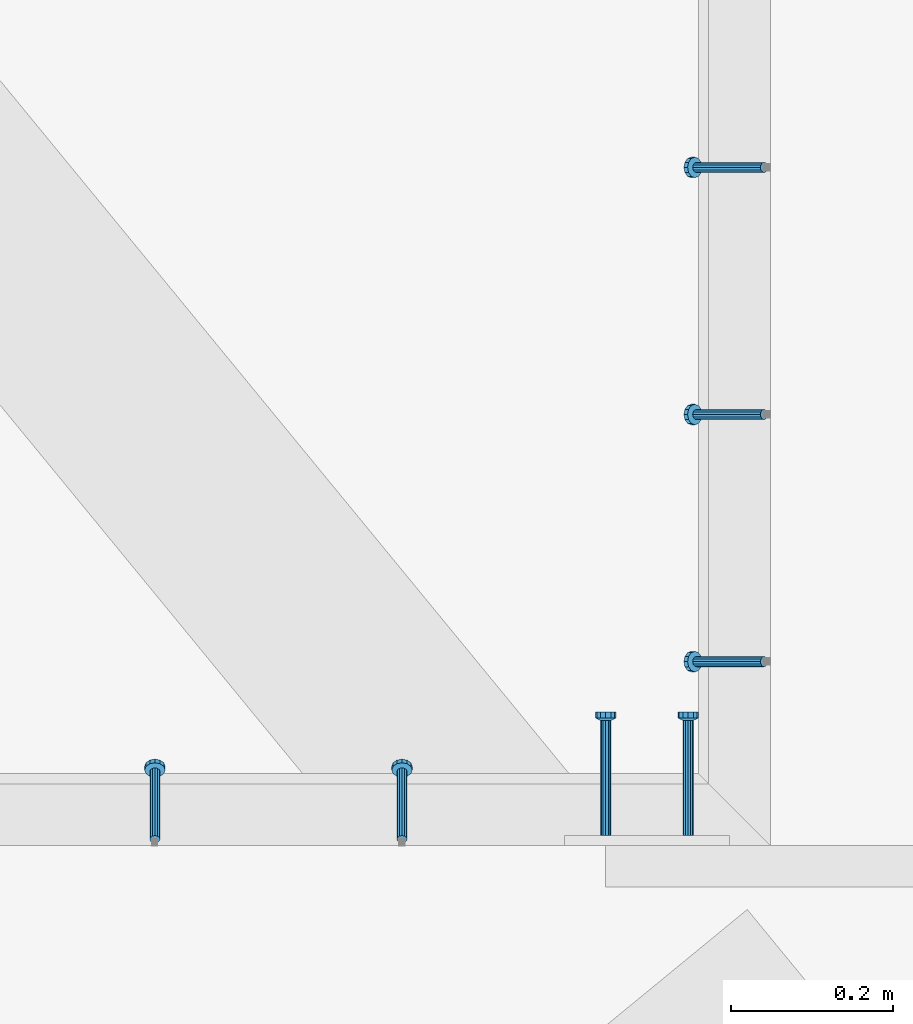
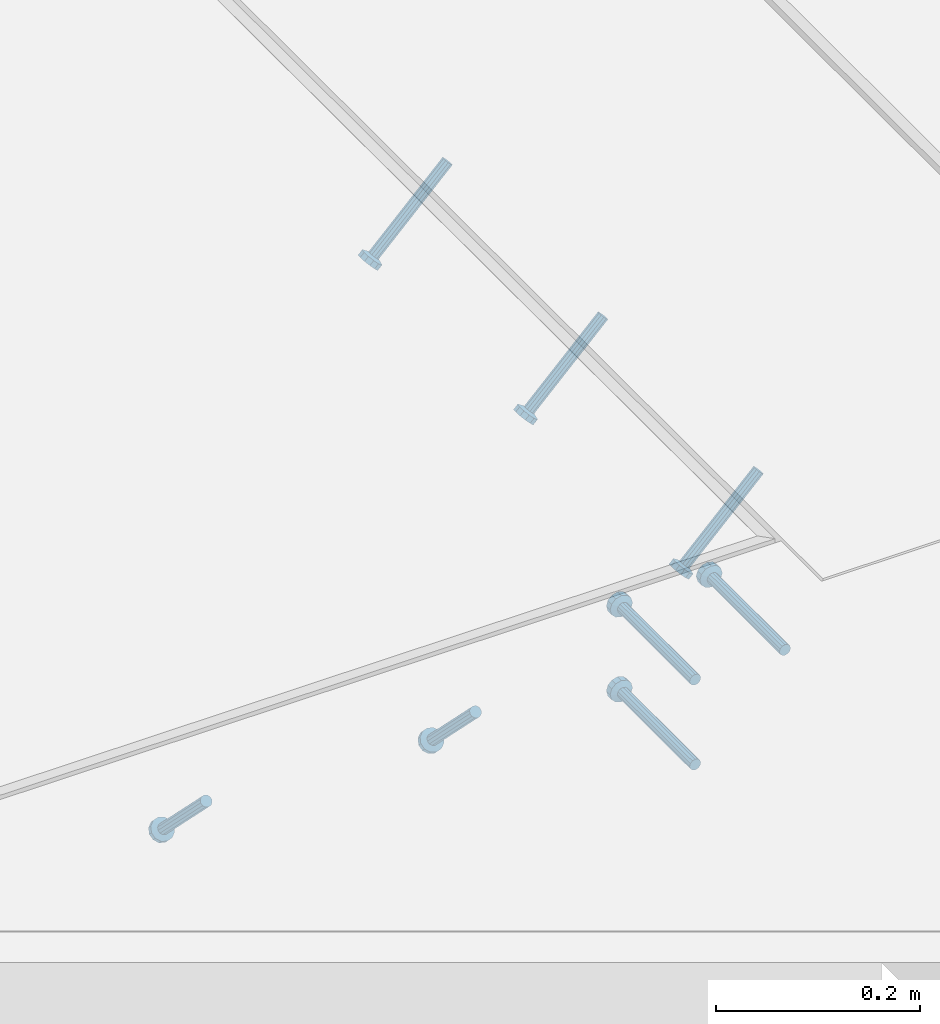
# One storey, part 2110 of 3843: 5 members, 3 beams, 3 elements without a shape of their own.
"""IFC2X3 building model written with IfcOpenShell, lengths in millimetres."""

from ifc_helpers import new_model, si_unit, frame, origin_with_axes, place, context, subcontext, project, spatial, faceted_brep, material, type_object, element, aggregate, save


model = new_model("IFC2X3")

# Units and contexts
model_context = context("Model", 3, precision=1e-05, world=origin_with_axes())
body_context = subcontext(model_context, "Body", "Model", "MODEL_VIEW")
ifc_project = project(units=[si_unit("LENGTHUNIT", "METRE", prefix="MILLI"), si_unit("AREAUNIT", "SQUARE_METRE"), si_unit("VOLUMEUNIT", "CUBIC_METRE"), si_unit("MASSUNIT", "GRAM", prefix="KILO"), si_unit("TIMEUNIT", "SECOND"), si_unit("PLANEANGLEUNIT", "RADIAN"), si_unit("SOLIDANGLEUNIT", "STERADIAN"), si_unit("THERMODYNAMICTEMPERATUREUNIT", "DEGREE_CELSIUS"), si_unit("LUMINOUSINTENSITYUNIT", "LUMEN")], contexts=[model_context])

# Site, building, storey
site_placement = place(None, origin_with_axes())
site = spatial("IfcSite", under=ifc_project, at=site_placement, CompositionType="ELEMENT")
building_placement = place(site_placement, origin_with_axes())
building = spatial("IfcBuilding", under=site, at=building_placement, Name="Undefined", CompositionType="ELEMENT")
storey_placement = place(building_placement, origin_with_axes())
storey = spatial("IfcBuildingStorey", under=building, at=storey_placement, Name="Undefined", CompositionType="ELEMENT", Elevation=0.0)

# Assembly, members
assembly_1_placement = place(storey_placement, origin_with_axes())
assembly_1 = element("IfcElementAssembly", 1, at=assembly_1_placement, inside=storey, Name="EMBED_ANGLE", AssemblyPlace="NOTDEFINED", PredefinedType="RIGID_FRAME")
ifc_material = material(Name="STEEL/A108")
member_type = type_object("IfcMemberType", PredefinedType="NOTDEFINED")
member_1_placement = place(assembly_1_placement, frame((48335.3742270521, 27662.1873782568, 30446.6625), z_axis=(0.0, -1.0, 0.0), x_axis=(-0.707106781186548, 0.0, -0.707106781186548)))
member_1 = element("IfcMember", 2, at=member_1_placement, type_object=member_type, material=ifc_material, Name="HEADED STUD ANCHOR", context=body_context, shape_type="Brep", body=[
    faceted_brep([(7.27595761418343e-12, -3.18000006675175, 5.5), (0.0, -5.49999999998363, 3.1800000667572), (118.110000000976, -5.49999999999091, 3.1800000667572), (118.110000000983, -3.18000006675175, 5.5), (0.0, -6.3499999046162, 0.0), (118.110000000968, -6.34999990461256, 0.0), (0.0, -5.49999999998363, -3.1800000667572), (118.110000000976, -5.49999999999091, -3.1800000667572), (7.27595761418343e-12, -3.18000006675175, -5.5), (118.110000000983, -3.18000006675175, -5.5), (7.27595761418343e-12, -1.81898940354586e-12, -6.34999990463257), (118.110000000968, -1.81898940354586e-12, -6.34999990463257), (0.0, 3.18000006675175, -5.5), (118.110000000968, 3.18000006674811, -5.5), (7.27595761418343e-12, 5.49999999998363, -3.1800000667572), (118.110000000983, 5.49999999998363, -3.1800000667572), (7.27595761418343e-12, 6.3499999046162, 0.0), (118.110000000976, 6.34999990461256, 0.0), (7.27595761418343e-12, 5.49999999998363, 3.1800000667572), (118.110000000983, 5.49999999998363, 3.1800000667572), (0.0, 3.18000006675175, 5.5), (118.110000000968, 3.18000006674811, 5.5), (7.27595761418343e-12, -1.81898940354586e-12, 6.34999990463257), (118.110000000968, -1.81898940354586e-12, 6.34999990463257), (120.650000000991, -10.9899997710909, 6.34999990463257), (120.650000000998, -6.34000015257152, 10.9899997711182), (120.650000000991, -12.6999998092379, 0.0), (120.650000000991, -10.9899997710909, -6.34999990463257), (120.650000000998, -6.34000015257152, -10.9899997711182), (120.650000000991, -1.81898940354586e-12, -12.6899995803833), (120.650000000991, 6.34000015257152, -10.9899997711182), (120.650000000998, 10.9899997710909, -6.34999990463257), (120.650000000991, 12.6999998092342, 0.0), (120.650000000998, 10.9899997710909, 6.34999990463257), (120.650000000991, 6.34000015257152, 10.9899997711182), (120.650000000991, -1.81898940354586e-12, 12.6899995803833), (127.000000001048, -10.9899997710945, 6.34999990463257), (127.000000001048, -6.34000015257152, 10.9899997711182), (127.000000001048, -12.6999998092342, 0.0), (127.000000001048, -10.9899997710945, -6.34999990463257), (127.000000001048, -6.34000015257152, -10.9899997711182), (127.000000001048, 1.81898940354586e-12, -12.6899995803833), (127.000000001048, 6.34000015256788, -10.9899997711182), (127.000000001048, 10.9899997710909, -6.34999990463257), (127.000000001048, 12.6999998092379, 0.0), (127.000000001048, 10.9899997710909, 6.34999990463257), (127.000000001048, 6.34000015256788, 10.9899997711182), (127.000000001048, 1.81898940354586e-12, 12.6899995803833)], [[[0, 1, 2, 3]], [[1, 4, 5, 2]], [[4, 6, 7, 5]], [[6, 8, 9, 7]], [[8, 10, 11, 9]], [[10, 12, 13, 11]], [[12, 14, 15, 13]], [[14, 16, 17, 15]], [[16, 18, 19, 17]], [[18, 20, 21, 19]], [[20, 22, 23, 21]], [[22, 0, 3, 23]], [[22, 20, 18, 16, 14, 12, 10, 8, 6, 4, 1, 0]], [[3, 2, 24, 25]], [[2, 5, 26, 24]], [[5, 7, 27, 26]], [[7, 9, 28, 27]], [[9, 11, 29, 28]], [[11, 13, 30, 29]], [[13, 15, 31, 30]], [[15, 17, 32, 31]], [[17, 19, 33, 32]], [[19, 21, 34, 33]], [[21, 23, 35, 34]], [[23, 3, 25, 35]], [[25, 24, 36, 37]], [[24, 26, 38, 36]], [[26, 27, 39, 38]], [[27, 28, 40, 39]], [[28, 29, 41, 40]], [[29, 30, 42, 41]], [[30, 31, 43, 42]], [[31, 32, 44, 43]], [[32, 33, 45, 44]], [[33, 34, 46, 45]], [[34, 35, 47, 46]], [[35, 25, 37, 47]], [[38, 39, 40, 41, 42, 43, 44, 45, 46, 47, 37, 36]]]),
])
member_2_placement = place(assembly_1_placement, frame((48335.3742270521, 27357.3873782568, 30446.6625), z_axis=(0.0, -1.0, 0.0), x_axis=(-0.707106781186548, 0.0, -0.707106781186548)))
member_2 = element("IfcMember", 3, at=member_2_placement, type_object=member_type, material=ifc_material, Name="HEADED STUD ANCHOR", context=body_context, shape_type="Brep", body=[
    faceted_brep([(7.27595761418343e-12, -3.18000006675175, 5.5), (0.0, -5.49999999998363, 3.1800000667572), (118.110000000976, -5.49999999999091, 3.1800000667572), (118.110000000983, -3.18000006675175, 5.5), (0.0, -6.3499999046162, 0.0), (118.110000000968, -6.34999990461256, 0.0), (0.0, -5.49999999998363, -3.1800000667572), (118.110000000976, -5.49999999999091, -3.1800000667572), (7.27595761418343e-12, -3.18000006675175, -5.5), (118.110000000983, -3.18000006675175, -5.5), (7.27595761418343e-12, -1.81898940354586e-12, -6.34999990463257), (118.110000000968, -1.81898940354586e-12, -6.34999990463257), (0.0, 3.18000006675175, -5.5), (118.110000000968, 3.18000006674811, -5.5), (7.27595761418343e-12, 5.49999999998363, -3.1800000667572), (118.110000000983, 5.49999999998363, -3.1800000667572), (7.27595761418343e-12, 6.3499999046162, 0.0), (118.110000000976, 6.34999990461256, 0.0), (7.27595761418343e-12, 5.49999999998363, 3.1800000667572), (118.110000000983, 5.49999999998363, 3.1800000667572), (0.0, 3.18000006675175, 5.5), (118.110000000968, 3.18000006674811, 5.5), (7.27595761418343e-12, -1.81898940354586e-12, 6.34999990463257), (118.110000000968, -1.81898940354586e-12, 6.34999990463257), (120.650000000991, -10.9899997710909, 6.34999990463257), (120.650000000998, -6.34000015257152, 10.9899997711182), (120.650000000991, -12.6999998092379, 0.0), (120.650000000991, -10.9899997710909, -6.34999990463257), (120.650000000998, -6.34000015257152, -10.9899997711182), (120.650000000991, -1.81898940354586e-12, -12.6899995803833), (120.650000000991, 6.34000015257152, -10.9899997711182), (120.650000000998, 10.9899997710909, -6.34999990463257), (120.650000000991, 12.6999998092342, 0.0), (120.650000000998, 10.9899997710909, 6.34999990463257), (120.650000000991, 6.34000015257152, 10.9899997711182), (120.650000000991, -1.81898940354586e-12, 12.6899995803833), (127.000000001048, -10.9899997710945, 6.34999990463257), (127.000000001048, -6.34000015257152, 10.9899997711182), (127.000000001048, -12.6999998092342, 0.0), (127.000000001048, -10.9899997710945, -6.34999990463257), (127.000000001048, -6.34000015257152, -10.9899997711182), (127.000000001048, 1.81898940354586e-12, -12.6899995803833), (127.000000001048, 6.34000015256788, -10.9899997711182), (127.000000001048, 10.9899997710909, -6.34999990463257), (127.000000001048, 12.6999998092379, 0.0), (127.000000001048, 10.9899997710909, 6.34999990463257), (127.000000001048, 6.34000015256788, 10.9899997711182), (127.000000001048, 1.81898940354586e-12, 12.6899995803833)], [[[0, 1, 2, 3]], [[1, 4, 5, 2]], [[4, 6, 7, 5]], [[6, 8, 9, 7]], [[8, 10, 11, 9]], [[10, 12, 13, 11]], [[12, 14, 15, 13]], [[14, 16, 17, 15]], [[16, 18, 19, 17]], [[18, 20, 21, 19]], [[20, 22, 23, 21]], [[22, 0, 3, 23]], [[22, 20, 18, 16, 14, 12, 10, 8, 6, 4, 1, 0]], [[3, 2, 24, 25]], [[2, 5, 26, 24]], [[5, 7, 27, 26]], [[7, 9, 28, 27]], [[9, 11, 29, 28]], [[11, 13, 30, 29]], [[13, 15, 31, 30]], [[15, 17, 32, 31]], [[17, 19, 33, 32]], [[19, 21, 34, 33]], [[21, 23, 35, 34]], [[23, 3, 25, 35]], [[25, 24, 36, 37]], [[24, 26, 38, 36]], [[26, 27, 39, 38]], [[27, 28, 40, 39]], [[28, 29, 41, 40]], [[29, 30, 42, 41]], [[30, 31, 43, 42]], [[31, 32, 44, 43]], [[32, 33, 45, 44]], [[33, 34, 46, 45]], [[34, 35, 47, 46]], [[35, 25, 37, 47]], [[38, 39, 40, 41, 42, 43, 44, 45, 46, 47, 37, 36]]]),
])
member_3_placement = place(assembly_1_placement, frame((48335.3742270521, 27052.5873782568, 30446.6625), z_axis=(0.0, -1.0, 0.0), x_axis=(-0.707106781186548, 0.0, -0.707106781186548)))
member_3 = element("IfcMember", 4, at=member_3_placement, type_object=member_type, material=ifc_material, Name="HEADED STUD ANCHOR", context=body_context, shape_type="Brep", body=[
    faceted_brep([(7.27595761418343e-12, -3.18000006675175, 5.5), (0.0, -5.49999999998363, 3.1800000667572), (118.110000000976, -5.49999999999091, 3.1800000667572), (118.110000000983, -3.18000006675175, 5.5), (0.0, -6.3499999046162, 0.0), (118.110000000968, -6.34999990461256, 0.0), (0.0, -5.49999999998363, -3.1800000667572), (118.110000000976, -5.49999999999091, -3.1800000667572), (7.27595761418343e-12, -3.18000006675175, -5.5), (118.110000000983, -3.18000006675175, -5.5), (7.27595761418343e-12, -1.81898940354586e-12, -6.34999990463257), (118.110000000968, -1.81898940354586e-12, -6.34999990463257), (0.0, 3.18000006675175, -5.5), (118.110000000968, 3.18000006674811, -5.5), (7.27595761418343e-12, 5.49999999998363, -3.1800000667572), (118.110000000983, 5.49999999998363, -3.1800000667572), (7.27595761418343e-12, 6.3499999046162, 0.0), (118.110000000976, 6.34999990461256, 0.0), (7.27595761418343e-12, 5.49999999998363, 3.1800000667572), (118.110000000983, 5.49999999998363, 3.1800000667572), (0.0, 3.18000006675175, 5.5), (118.110000000968, 3.18000006674811, 5.5), (7.27595761418343e-12, -1.81898940354586e-12, 6.34999990463257), (118.110000000968, -1.81898940354586e-12, 6.34999990463257), (120.650000000991, -10.9899997710909, 6.34999990463257), (120.650000000998, -6.34000015257152, 10.9899997711182), (120.650000000991, -12.6999998092379, 0.0), (120.650000000991, -10.9899997710909, -6.34999990463257), (120.650000000998, -6.34000015257152, -10.9899997711182), (120.650000000991, -1.81898940354586e-12, -12.6899995803833), (120.650000000991, 6.34000015257152, -10.9899997711182), (120.650000000998, 10.9899997710909, -6.34999990463257), (120.650000000991, 12.6999998092342, 0.0), (120.650000000998, 10.9899997710909, 6.34999990463257), (120.650000000991, 6.34000015257152, 10.9899997711182), (120.650000000991, -1.81898940354586e-12, 12.6899995803833), (127.000000001048, -10.9899997710945, 6.34999990463257), (127.000000001048, -6.34000015257152, 10.9899997711182), (127.000000001048, -12.6999998092342, 0.0), (127.000000001048, -10.9899997710945, -6.34999990463257), (127.000000001048, -6.34000015257152, -10.9899997711182), (127.000000001048, 1.81898940354586e-12, -12.6899995803833), (127.000000001048, 6.34000015256788, -10.9899997711182), (127.000000001048, 10.9899997710909, -6.34999990463257), (127.000000001048, 12.6999998092379, 0.0), (127.000000001048, 10.9899997710909, 6.34999990463257), (127.000000001048, 6.34000015256788, 10.9899997711182), (127.000000001048, 1.81898940354586e-12, 12.6899995803833)], [[[0, 1, 2, 3]], [[1, 4, 5, 2]], [[4, 6, 7, 5]], [[6, 8, 9, 7]], [[8, 10, 11, 9]], [[10, 12, 13, 11]], [[12, 14, 15, 13]], [[14, 16, 17, 15]], [[16, 18, 19, 17]], [[18, 20, 21, 19]], [[20, 22, 23, 21]], [[22, 0, 3, 23]], [[22, 20, 18, 16, 14, 12, 10, 8, 6, 4, 1, 0]], [[3, 2, 24, 25]], [[2, 5, 26, 24]], [[5, 7, 27, 26]], [[7, 9, 28, 27]], [[9, 11, 29, 28]], [[11, 13, 30, 29]], [[13, 15, 31, 30]], [[15, 17, 32, 31]], [[17, 19, 33, 32]], [[19, 21, 34, 33]], [[21, 23, 35, 34]], [[23, 3, 25, 35]], [[25, 24, 36, 37]], [[24, 26, 38, 36]], [[26, 27, 39, 38]], [[27, 28, 40, 39]], [[28, 29, 41, 40]], [[29, 30, 42, 41]], [[30, 31, 43, 42]], [[31, 32, 44, 43]], [[32, 33, 45, 44]], [[33, 34, 46, 45]], [[34, 35, 47, 46]], [[35, 25, 37, 47]], [[38, 39, 40, 41, 42, 43, 44, 45, 46, 47, 37, 36]]]),
])
aggregate(assembly_1, [member_1, member_2, member_3])

assembly_2_placement = place(storey_placement, origin_with_axes())
assembly_2 = element("IfcElementAssembly", 5, at=assembly_2_placement, inside=storey, Name="EMBED_ANGLE", AssemblyPlace="NOTDEFINED", PredefinedType="RIGID_FRAME")
member_4_placement = place(assembly_2_placement, frame((47888.7789711915, 26833.5120625, 30446.6625), z_axis=(-1.0, 0.0, 0.0), x_axis=(5.70000238222118e-08, 0.707106781186546, -0.707106781186546)))
member_4 = element("IfcMember", 6, at=member_4_placement, type_object=member_type, material=ifc_material, Name="HEADED STUD ANCHOR", context=body_context, shape_type="Brep", body=[
    faceted_brep([(7.27595761418343e-12, -3.18000006675175, 5.5), (0.0, -5.49999999998363, 3.1800000667572), (118.110000000976, -5.49999999999091, 3.1800000667572), (118.110000000983, -3.18000006675175, 5.5), (0.0, -6.3499999046162, 0.0), (118.110000000968, -6.34999990461256, 0.0), (0.0, -5.49999999998363, -3.1800000667572), (118.110000000976, -5.49999999999091, -3.1800000667572), (7.27595761418343e-12, -3.18000006675175, -5.5), (118.110000000983, -3.18000006675175, -5.5), (7.27595761418343e-12, -1.81898940354586e-12, -6.34999990463257), (118.110000000968, -1.81898940354586e-12, -6.34999990463257), (0.0, 3.18000006675175, -5.5), (118.110000000968, 3.18000006674811, -5.5), (7.27595761418343e-12, 5.49999999998363, -3.1800000667572), (118.110000000983, 5.49999999998363, -3.1800000667572), (7.27595761418343e-12, 6.3499999046162, 0.0), (118.110000000976, 6.34999990461256, 0.0), (7.27595761418343e-12, 5.49999999998363, 3.1800000667572), (118.110000000983, 5.49999999998363, 3.1800000667572), (0.0, 3.18000006675175, 5.5), (118.110000000968, 3.18000006674811, 5.5), (7.27595761418343e-12, -1.81898940354586e-12, 6.34999990463257), (118.110000000968, -1.81898940354586e-12, 6.34999990463257), (120.650000000991, -10.9899997710909, 6.34999990463257), (120.650000000998, -6.34000015257152, 10.9899997711182), (120.650000000991, -12.6999998092379, 0.0), (120.650000000991, -10.9899997710909, -6.34999990463257), (120.650000000998, -6.34000015257152, -10.9899997711182), (120.650000000991, -1.81898940354586e-12, -12.6899995803833), (120.650000000991, 6.34000015257152, -10.9899997711182), (120.650000000998, 10.9899997710909, -6.34999990463257), (120.650000000991, 12.6999998092342, 0.0), (120.650000000998, 10.9899997710909, 6.34999990463257), (120.650000000991, 6.34000015257152, 10.9899997711182), (120.650000000991, -1.81898940354586e-12, 12.6899995803833), (127.000000001048, -10.9899997710945, 6.34999990463257), (127.000000001048, -6.34000015257152, 10.9899997711182), (127.000000001048, -12.6999998092342, 0.0), (127.000000001048, -10.9899997710945, -6.34999990463257), (127.000000001048, -6.34000015257152, -10.9899997711182), (127.000000001048, 1.81898940354586e-12, -12.6899995803833), (127.000000001048, 6.34000015256788, -10.9899997711182), (127.000000001048, 10.9899997710909, -6.34999990463257), (127.000000001048, 12.6999998092379, 0.0), (127.000000001048, 10.9899997710909, 6.34999990463257), (127.000000001048, 6.34000015256788, 10.9899997711182), (127.000000001048, 1.81898940354586e-12, 12.6899995803833)], [[[0, 1, 2, 3]], [[1, 4, 5, 2]], [[4, 6, 7, 5]], [[6, 8, 9, 7]], [[8, 10, 11, 9]], [[10, 12, 13, 11]], [[12, 14, 15, 13]], [[14, 16, 17, 15]], [[16, 18, 19, 17]], [[18, 20, 21, 19]], [[20, 22, 23, 21]], [[22, 0, 3, 23]], [[22, 20, 18, 16, 14, 12, 10, 8, 6, 4, 1, 0]], [[3, 2, 24, 25]], [[2, 5, 26, 24]], [[5, 7, 27, 26]], [[7, 9, 28, 27]], [[9, 11, 29, 28]], [[11, 13, 30, 29]], [[13, 15, 31, 30]], [[15, 17, 32, 31]], [[17, 19, 33, 32]], [[19, 21, 34, 33]], [[21, 23, 35, 34]], [[23, 3, 25, 35]], [[25, 24, 36, 37]], [[24, 26, 38, 36]], [[26, 27, 39, 38]], [[27, 28, 40, 39]], [[28, 29, 41, 40]], [[29, 30, 42, 41]], [[30, 31, 43, 42]], [[31, 32, 44, 43]], [[32, 33, 45, 44]], [[33, 34, 46, 45]], [[34, 35, 47, 46]], [[35, 25, 37, 47]], [[38, 39, 40, 41, 42, 43, 44, 45, 46, 47, 37, 36]]]),
])
member_5_placement = place(assembly_2_placement, frame((47583.9789711915, 26833.5120625, 30446.6625), z_axis=(-1.0, 0.0, 0.0), x_axis=(5.70000238222118e-08, 0.707106781186546, -0.707106781186546)))
member_5 = element("IfcMember", 7, at=member_5_placement, type_object=member_type, material=ifc_material, Name="HEADED STUD ANCHOR", context=body_context, shape_type="Brep", body=[
    faceted_brep([(7.27595761418343e-12, -3.18000006675175, 5.5), (0.0, -5.49999999998363, 3.1800000667572), (118.110000000976, -5.49999999999091, 3.1800000667572), (118.110000000983, -3.18000006675175, 5.5), (0.0, -6.3499999046162, 0.0), (118.110000000968, -6.34999990461256, 0.0), (0.0, -5.49999999998363, -3.1800000667572), (118.110000000976, -5.49999999999091, -3.1800000667572), (7.27595761418343e-12, -3.18000006675175, -5.5), (118.110000000983, -3.18000006675175, -5.5), (7.27595761418343e-12, -1.81898940354586e-12, -6.34999990463257), (118.110000000968, -1.81898940354586e-12, -6.34999990463257), (0.0, 3.18000006675175, -5.5), (118.110000000968, 3.18000006674811, -5.5), (7.27595761418343e-12, 5.49999999998363, -3.1800000667572), (118.110000000983, 5.49999999998363, -3.1800000667572), (7.27595761418343e-12, 6.3499999046162, 0.0), (118.110000000976, 6.34999990461256, 0.0), (7.27595761418343e-12, 5.49999999998363, 3.1800000667572), (118.110000000983, 5.49999999998363, 3.1800000667572), (0.0, 3.18000006675175, 5.5), (118.110000000968, 3.18000006674811, 5.5), (7.27595761418343e-12, -1.81898940354586e-12, 6.34999990463257), (118.110000000968, -1.81898940354586e-12, 6.34999990463257), (120.650000000991, -10.9899997710909, 6.34999990463257), (120.650000000998, -6.34000015257152, 10.9899997711182), (120.650000000991, -12.6999998092379, 0.0), (120.650000000991, -10.9899997710909, -6.34999990463257), (120.650000000998, -6.34000015257152, -10.9899997711182), (120.650000000991, -1.81898940354586e-12, -12.6899995803833), (120.650000000991, 6.34000015257152, -10.9899997711182), (120.650000000998, 10.9899997710909, -6.34999990463257), (120.650000000991, 12.6999998092342, 0.0), (120.650000000998, 10.9899997710909, 6.34999990463257), (120.650000000991, 6.34000015257152, 10.9899997711182), (120.650000000991, -1.81898940354586e-12, 12.6899995803833), (127.000000001048, -10.9899997710945, 6.34999990463257), (127.000000001048, -6.34000015257152, 10.9899997711182), (127.000000001048, -12.6999998092342, 0.0), (127.000000001048, -10.9899997710945, -6.34999990463257), (127.000000001048, -6.34000015257152, -10.9899997711182), (127.000000001048, 1.81898940354586e-12, -12.6899995803833), (127.000000001048, 6.34000015256788, -10.9899997711182), (127.000000001048, 10.9899997710909, -6.34999990463257), (127.000000001048, 12.6999998092379, 0.0), (127.000000001048, 10.9899997710909, 6.34999990463257), (127.000000001048, 6.34000015256788, 10.9899997711182), (127.000000001048, 1.81898940354586e-12, 12.6899995803833)], [[[0, 1, 2, 3]], [[1, 4, 5, 2]], [[4, 6, 7, 5]], [[6, 8, 9, 7]], [[8, 10, 11, 9]], [[10, 12, 13, 11]], [[12, 14, 15, 13]], [[14, 16, 17, 15]], [[16, 18, 19, 17]], [[18, 20, 21, 19]], [[20, 22, 23, 21]], [[22, 0, 3, 23]], [[22, 20, 18, 16, 14, 12, 10, 8, 6, 4, 1, 0]], [[3, 2, 24, 25]], [[2, 5, 26, 24]], [[5, 7, 27, 26]], [[7, 9, 28, 27]], [[9, 11, 29, 28]], [[11, 13, 30, 29]], [[13, 15, 31, 30]], [[15, 17, 32, 31]], [[17, 19, 33, 32]], [[19, 21, 34, 33]], [[21, 23, 35, 34]], [[23, 3, 25, 35]], [[25, 24, 36, 37]], [[24, 26, 38, 36]], [[26, 27, 39, 38]], [[27, 28, 40, 39]], [[28, 29, 41, 40]], [[29, 30, 42, 41]], [[30, 31, 43, 42]], [[31, 32, 44, 43]], [[32, 33, 45, 44]], [[33, 34, 46, 45]], [[34, 35, 47, 46]], [[35, 25, 37, 47]], [[38, 39, 40, 41, 42, 43, 44, 45, 46, 47, 37, 36]]]),
])
aggregate(assembly_2, [member_4, member_5])

# Assembly, beams
assembly_3_placement = place(storey_placement, origin_with_axes())
assembly_3 = element("IfcElementAssembly", 8, at=assembly_3_placement, inside=storey, Name="EMBED PLATE", AssemblyPlace="NOTDEFINED", PredefinedType="RIGID_FRAME")
beam_type = type_object("IfcBeamType", PredefinedType="NOTDEFINED")
beam_1_placement = place(assembly_3_placement, frame((48140.111942391, 26838.2760728433, 30394.275), z_axis=(-1.0, 0.0, 0.0), x_axis=(0.0, 1.0, 0.0)))
beam_1 = element("IfcBeam", 9, at=beam_1_placement, type_object=beam_type, material=ifc_material, Name="HEADED STUD ANCHOR", context=body_context, shape_type="Brep", body=[
    faceted_brep([(7.27595761418343e-12, -3.18000006675175, 5.5), (0.0, -5.49999999998363, 3.1800000667572), (141.731999999989, -5.5, 3.1800000667572), (141.731999999989, -3.1800000667572, 5.5), (0.0, -6.3499999046162, 0.0), (141.731999999989, -6.34999990463257, 0.0), (0.0, -5.49999999998363, -3.1800000667572), (141.731999999989, -5.5, -3.1800000667572), (7.27595761418343e-12, -3.18000006675175, -5.5), (141.731999999989, -3.1800000667572, -5.5), (7.27595761418343e-12, -1.81898940354586e-12, -6.34999990463257), (141.731999999989, 0.0, -6.34999990463257), (0.0, 3.18000006675175, -5.5), (141.731999999989, 3.1800000667572, -5.5), (7.27595761418343e-12, 5.49999999998363, -3.1800000667572), (141.731999999989, 5.5, -3.1800000667572), (7.27595761418343e-12, 6.3499999046162, 0.0), (141.731999999989, 6.34999990463257, 0.0), (7.27595761418343e-12, 5.49999999998363, 3.1800000667572), (141.731999999989, 5.5, 3.1800000667572), (0.0, 3.18000006675175, 5.5), (141.731999999989, 3.1800000667572, 5.5), (7.27595761418343e-12, -1.81898940354586e-12, 6.34999990463257), (141.731999999989, 0.0, 6.34999990463257), (144.779999999999, -10.9899997711182, 6.34999990463257), (144.779999999999, -6.34000015258789, 10.9899997711182), (144.779999999999, -12.6999998092651, 0.0), (144.779999999999, -10.9899997711182, -6.34999990463257), (144.779999999999, -6.34000015258789, -10.9899997711182), (144.779999999999, 0.0, -12.6899995803833), (144.779999999999, 6.34000015258789, -10.9899997711182), (144.779999999999, 10.9899997711182, -6.34999990463257), (144.779999999999, 12.6999998092651, 0.0), (144.779999999999, 10.9899997711182, 6.34999990463257), (144.779999999999, 6.34000015258789, 10.9899997711182), (144.779999999999, 0.0, 12.6899995803833), (152.399999999994, -10.9899997711182, 6.34999990463257), (152.399999999994, -6.34000015258789, 10.9899997711182), (152.399999999994, -12.6999998092651, 0.0), (152.399999999994, -10.9899997711182, -6.34999990463257), (152.399999999994, -6.34000015258789, -10.9899997711182), (152.399999999994, 0.0, -12.6899995803833), (152.399999999994, 6.34000015258789, -10.9899997711182), (152.399999999994, 10.9899997711182, -6.34999990463257), (152.399999999994, 12.6999998092651, 0.0), (152.399999999994, 10.9899997711182, 6.34999990463257), (152.399999999994, 6.34000015258789, 10.9899997711182), (152.399999999994, 0.0, 12.6899995803833)], [[[0, 1, 2, 3]], [[1, 4, 5, 2]], [[4, 6, 7, 5]], [[6, 8, 9, 7]], [[8, 10, 11, 9]], [[10, 12, 13, 11]], [[12, 14, 15, 13]], [[14, 16, 17, 15]], [[16, 18, 19, 17]], [[18, 20, 21, 19]], [[20, 22, 23, 21]], [[22, 0, 3, 23]], [[22, 20, 18, 16, 14, 12, 10, 8, 6, 4, 1, 0]], [[3, 2, 24, 25]], [[2, 5, 26, 24]], [[5, 7, 27, 26]], [[7, 9, 28, 27]], [[9, 11, 29, 28]], [[11, 13, 30, 29]], [[13, 15, 31, 30]], [[15, 17, 32, 31]], [[17, 19, 33, 32]], [[19, 21, 34, 33]], [[21, 23, 35, 34]], [[23, 3, 25, 35]], [[25, 24, 36, 37]], [[24, 26, 38, 36]], [[26, 27, 39, 38]], [[27, 28, 40, 39]], [[28, 29, 41, 40]], [[29, 30, 42, 41]], [[30, 31, 43, 42]], [[31, 32, 44, 43]], [[32, 33, 45, 44]], [[33, 34, 46, 45]], [[34, 35, 47, 46]], [[35, 25, 37, 47]], [[38, 39, 40, 41, 42, 43, 44, 45, 46, 47, 37, 36]]]),
])
beam_2_placement = place(assembly_3_placement, frame((48140.111942391, 26838.2760728433, 30292.675), z_axis=(-1.0, 0.0, 0.0), x_axis=(0.0, 1.0, 0.0)))
beam_2 = element("IfcBeam", 10, at=beam_2_placement, type_object=beam_type, material=ifc_material, Name="HEADED STUD ANCHOR", context=body_context, shape_type="Brep", body=[
    faceted_brep([(7.27595761418343e-12, -3.18000006675175, 5.5), (0.0, -5.49999999998363, 3.1800000667572), (141.731999999989, -5.5, 3.1800000667572), (141.731999999989, -3.1800000667572, 5.5), (0.0, -6.3499999046162, 0.0), (141.731999999989, -6.34999990463257, 0.0), (0.0, -5.49999999998363, -3.1800000667572), (141.731999999989, -5.5, -3.1800000667572), (7.27595761418343e-12, -3.18000006675175, -5.5), (141.731999999989, -3.1800000667572, -5.5), (7.27595761418343e-12, -1.81898940354586e-12, -6.34999990463257), (141.731999999989, 0.0, -6.34999990463257), (0.0, 3.18000006675175, -5.5), (141.731999999989, 3.1800000667572, -5.5), (7.27595761418343e-12, 5.49999999998363, -3.1800000667572), (141.731999999989, 5.5, -3.1800000667572), (7.27595761418343e-12, 6.3499999046162, 0.0), (141.731999999989, 6.34999990463257, 0.0), (7.27595761418343e-12, 5.49999999998363, 3.1800000667572), (141.731999999989, 5.5, 3.1800000667572), (0.0, 3.18000006675175, 5.5), (141.731999999989, 3.1800000667572, 5.5), (7.27595761418343e-12, -1.81898940354586e-12, 6.34999990463257), (141.731999999989, 0.0, 6.34999990463257), (144.779999999999, -10.9899997711182, 6.34999990463257), (144.779999999999, -6.34000015258789, 10.9899997711182), (144.779999999999, -12.6999998092651, 0.0), (144.779999999999, -10.9899997711182, -6.34999990463257), (144.779999999999, -6.34000015258789, -10.9899997711182), (144.779999999999, 0.0, -12.6899995803833), (144.779999999999, 6.34000015258789, -10.9899997711182), (144.779999999999, 10.9899997711182, -6.34999990463257), (144.779999999999, 12.6999998092651, 0.0), (144.779999999999, 10.9899997711182, 6.34999990463257), (144.779999999999, 6.34000015258789, 10.9899997711182), (144.779999999999, 0.0, 12.6899995803833), (152.399999999994, -10.9899997711182, 6.34999990463257), (152.399999999994, -6.34000015258789, 10.9899997711182), (152.399999999994, -12.6999998092651, 0.0), (152.399999999994, -10.9899997711182, -6.34999990463257), (152.399999999994, -6.34000015258789, -10.9899997711182), (152.399999999994, 0.0, -12.6899995803833), (152.399999999994, 6.34000015258789, -10.9899997711182), (152.399999999994, 10.9899997711182, -6.34999990463257), (152.399999999994, 12.6999998092651, 0.0), (152.399999999994, 10.9899997711182, 6.34999990463257), (152.399999999994, 6.34000015258789, 10.9899997711182), (152.399999999994, 0.0, 12.6899995803833)], [[[0, 1, 2, 3]], [[1, 4, 5, 2]], [[4, 6, 7, 5]], [[6, 8, 9, 7]], [[8, 10, 11, 9]], [[10, 12, 13, 11]], [[12, 14, 15, 13]], [[14, 16, 17, 15]], [[16, 18, 19, 17]], [[18, 20, 21, 19]], [[20, 22, 23, 21]], [[22, 0, 3, 23]], [[22, 20, 18, 16, 14, 12, 10, 8, 6, 4, 1, 0]], [[3, 2, 24, 25]], [[2, 5, 26, 24]], [[5, 7, 27, 26]], [[7, 9, 28, 27]], [[9, 11, 29, 28]], [[11, 13, 30, 29]], [[13, 15, 31, 30]], [[15, 17, 32, 31]], [[17, 19, 33, 32]], [[19, 21, 34, 33]], [[21, 23, 35, 34]], [[23, 3, 25, 35]], [[25, 24, 36, 37]], [[24, 26, 38, 36]], [[26, 27, 39, 38]], [[27, 28, 40, 39]], [[28, 29, 41, 40]], [[29, 30, 42, 41]], [[30, 31, 43, 42]], [[31, 32, 44, 43]], [[32, 33, 45, 44]], [[33, 34, 46, 45]], [[34, 35, 47, 46]], [[35, 25, 37, 47]], [[38, 39, 40, 41, 42, 43, 44, 45, 46, 47, 37, 36]]]),
])
beam_3_placement = place(assembly_3_placement, frame((48241.711942391, 26838.2760728433, 30394.275), z_axis=(-1.0, 0.0, 0.0), x_axis=(0.0, 1.0, 0.0)))
beam_3 = element("IfcBeam", 11, at=beam_3_placement, type_object=beam_type, material=ifc_material, Name="HEADED STUD ANCHOR", context=body_context, shape_type="Brep", body=[
    faceted_brep([(7.27595761418343e-12, -3.18000006675175, 5.5), (0.0, -5.49999999998363, 3.1800000667572), (141.731999999989, -5.5, 3.1800000667572), (141.731999999989, -3.1800000667572, 5.5), (0.0, -6.3499999046162, 0.0), (141.731999999989, -6.34999990463257, 0.0), (0.0, -5.49999999998363, -3.1800000667572), (141.731999999989, -5.5, -3.1800000667572), (7.27595761418343e-12, -3.18000006675175, -5.5), (141.731999999989, -3.1800000667572, -5.5), (7.27595761418343e-12, -1.81898940354586e-12, -6.34999990463257), (141.731999999989, 0.0, -6.34999990463257), (0.0, 3.18000006675175, -5.5), (141.731999999989, 3.1800000667572, -5.5), (7.27595761418343e-12, 5.49999999998363, -3.1800000667572), (141.731999999989, 5.5, -3.1800000667572), (7.27595761418343e-12, 6.3499999046162, 0.0), (141.731999999989, 6.34999990463257, 0.0), (7.27595761418343e-12, 5.49999999998363, 3.1800000667572), (141.731999999989, 5.5, 3.1800000667572), (0.0, 3.18000006675175, 5.5), (141.731999999989, 3.1800000667572, 5.5), (7.27595761418343e-12, -1.81898940354586e-12, 6.34999990463257), (141.731999999989, 0.0, 6.34999990463257), (144.779999999999, -10.9899997711182, 6.34999990463257), (144.779999999999, -6.34000015258789, 10.9899997711182), (144.779999999999, -12.6999998092651, 0.0), (144.779999999999, -10.9899997711182, -6.34999990463257), (144.779999999999, -6.34000015258789, -10.9899997711182), (144.779999999999, 0.0, -12.6899995803833), (144.779999999999, 6.34000015258789, -10.9899997711182), (144.779999999999, 10.9899997711182, -6.34999990463257), (144.779999999999, 12.6999998092651, 0.0), (144.779999999999, 10.9899997711182, 6.34999990463257), (144.779999999999, 6.34000015258789, 10.9899997711182), (144.779999999999, 0.0, 12.6899995803833), (152.399999999994, -10.9899997711182, 6.34999990463257), (152.399999999994, -6.34000015258789, 10.9899997711182), (152.399999999994, -12.6999998092651, 0.0), (152.399999999994, -10.9899997711182, -6.34999990463257), (152.399999999994, -6.34000015258789, -10.9899997711182), (152.399999999994, 0.0, -12.6899995803833), (152.399999999994, 6.34000015258789, -10.9899997711182), (152.399999999994, 10.9899997711182, -6.34999990463257), (152.399999999994, 12.6999998092651, 0.0), (152.399999999994, 10.9899997711182, 6.34999990463257), (152.399999999994, 6.34000015258789, 10.9899997711182), (152.399999999994, 0.0, 12.6899995803833)], [[[0, 1, 2, 3]], [[1, 4, 5, 2]], [[4, 6, 7, 5]], [[6, 8, 9, 7]], [[8, 10, 11, 9]], [[10, 12, 13, 11]], [[12, 14, 15, 13]], [[14, 16, 17, 15]], [[16, 18, 19, 17]], [[18, 20, 21, 19]], [[20, 22, 23, 21]], [[22, 0, 3, 23]], [[22, 20, 18, 16, 14, 12, 10, 8, 6, 4, 1, 0]], [[3, 2, 24, 25]], [[2, 5, 26, 24]], [[5, 7, 27, 26]], [[7, 9, 28, 27]], [[9, 11, 29, 28]], [[11, 13, 30, 29]], [[13, 15, 31, 30]], [[15, 17, 32, 31]], [[17, 19, 33, 32]], [[19, 21, 34, 33]], [[21, 23, 35, 34]], [[23, 3, 25, 35]], [[25, 24, 36, 37]], [[24, 26, 38, 36]], [[26, 27, 39, 38]], [[27, 28, 40, 39]], [[28, 29, 41, 40]], [[29, 30, 42, 41]], [[30, 31, 43, 42]], [[31, 32, 44, 43]], [[32, 33, 45, 44]], [[33, 34, 46, 45]], [[34, 35, 47, 46]], [[35, 25, 37, 47]], [[38, 39, 40, 41, 42, 43, 44, 45, 46, 47, 37, 36]]]),
])
aggregate(assembly_3, [beam_1, beam_2, beam_3])

save(model, "model.ifc")
